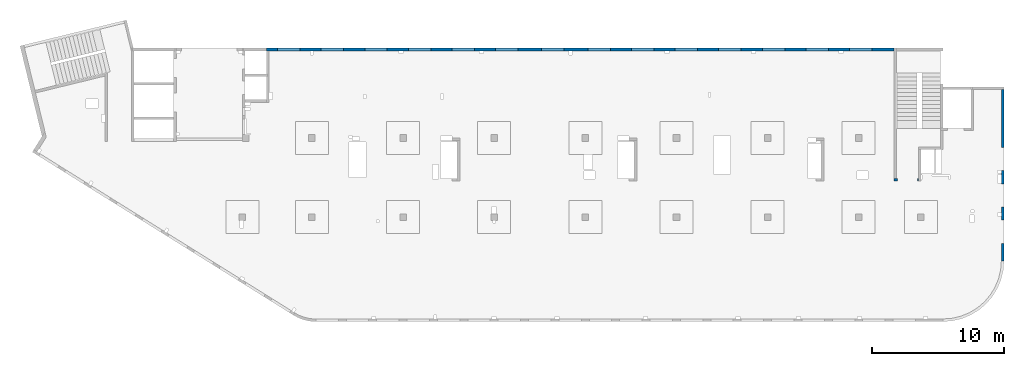
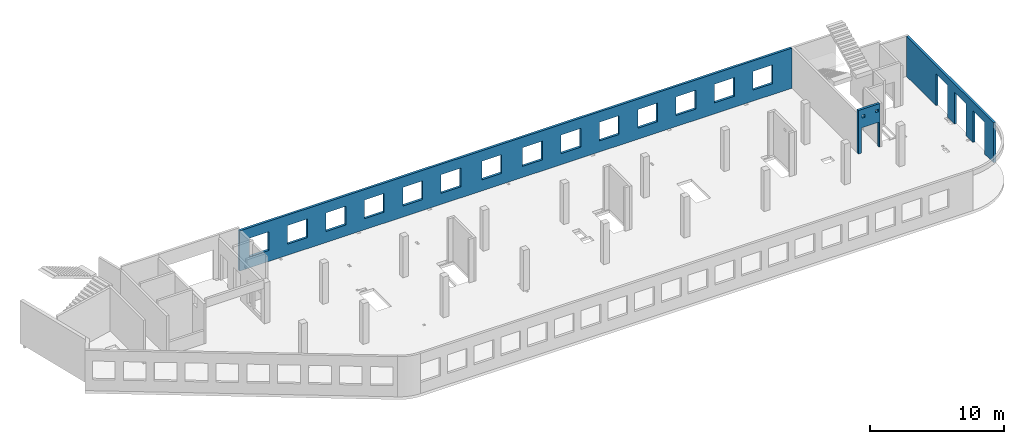
# One storey, part 7 of 7: 3 walls, 20 openings.
"""IFC4 building model written with IfcOpenShell, lengths in millimetres."""

from ifc_helpers import new_model, entity, si_unit, converted_unit, derived_unit, direction, frame, origin, place, context, subcontext, project, spatial, indexed_curve, outline, extrude, polygons, material, type_object, element, save


model = new_model("IFC4")

# Units and contexts
model_context = context("Model", 3, precision=0.01, world=origin(), true_north=direction((6.12303176911189e-17, 1.0)))
plan_context = context("Plan", 3, precision=0.01, world=origin(), true_north=direction((6.12303176911189e-17, 1.0)))
body_context = subcontext(model_context, "Body", "Model", "MODEL_VIEW")
ifc_project = project(units=[si_unit("LENGTHUNIT", "METRE", prefix="MILLI"), si_unit("AREAUNIT", "SQUARE_METRE"), si_unit("VOLUMEUNIT", "CUBIC_METRE"), converted_unit("PLANEANGLEUNIT", "DEGREE", entity("IfcRatioMeasure", 0.0174532925199433), si_unit("PLANEANGLEUNIT", "RADIAN"), dimensions=[0, 0, 0, 0, 0, 0, 0]), si_unit("MASSUNIT", "GRAM", prefix="KILO"), derived_unit("MASSDENSITYUNIT", [(si_unit("MASSUNIT", "GRAM", prefix="KILO"), 1), (si_unit("LENGTHUNIT", "METRE"), -3)]), derived_unit("MOMENTOFINERTIAUNIT", [(si_unit("LENGTHUNIT", "METRE"), 4)]), si_unit("TIMEUNIT", "SECOND"), si_unit("FREQUENCYUNIT", "HERTZ"), si_unit("THERMODYNAMICTEMPERATUREUNIT", "DEGREE_CELSIUS"), derived_unit("THERMALTRANSMITTANCEUNIT", [(si_unit("MASSUNIT", "GRAM", prefix="KILO"), 1), (si_unit("THERMODYNAMICTEMPERATUREUNIT", "KELVIN"), -1), (si_unit("TIMEUNIT", "SECOND"), -3)]), derived_unit("VOLUMETRICFLOWRATEUNIT", [(si_unit("LENGTHUNIT", "METRE"), 3), (si_unit("TIMEUNIT", "SECOND"), -1)]), derived_unit("MASSFLOWRATEUNIT", [(si_unit("MASSUNIT", "GRAM", prefix="KILO"), 1), (si_unit("TIMEUNIT", "SECOND"), -1)]), derived_unit("ROTATIONALFREQUENCYUNIT", [(si_unit("TIMEUNIT", "SECOND"), -1)]), si_unit("ELECTRICCURRENTUNIT", "AMPERE"), si_unit("ELECTRICVOLTAGEUNIT", "VOLT"), si_unit("POWERUNIT", "WATT"), si_unit("FORCEUNIT", "NEWTON", prefix="KILO"), si_unit("ILLUMINANCEUNIT", "LUX"), si_unit("LUMINOUSFLUXUNIT", "LUMEN"), si_unit("LUMINOUSINTENSITYUNIT", "CANDELA"), derived_unit("USERDEFINED", [(si_unit("MASSUNIT", "GRAM", prefix="KILO"), -1), (si_unit("LENGTHUNIT", "METRE"), -2), (si_unit("TIMEUNIT", "SECOND"), 3), (si_unit("LUMINOUSFLUXUNIT", "LUMEN"), 1)]), derived_unit("LINEARVELOCITYUNIT", [(si_unit("LENGTHUNIT", "METRE"), 1), (si_unit("TIMEUNIT", "SECOND"), -1)]), si_unit("PRESSUREUNIT", "PASCAL"), derived_unit("USERDEFINED", [(si_unit("LENGTHUNIT", "METRE"), -2), (si_unit("MASSUNIT", "GRAM", prefix="KILO"), 1), (si_unit("TIMEUNIT", "SECOND"), -2)]), derived_unit("LINEARFORCEUNIT", [(si_unit("MASSUNIT", "GRAM", prefix="KILO"), 1), (si_unit("LENGTHUNIT", "METRE"), 1), (si_unit("TIMEUNIT", "SECOND"), -2), (si_unit("LENGTHUNIT", "METRE"), -1)]), derived_unit("PLANARFORCEUNIT", [(si_unit("MASSUNIT", "GRAM", prefix="KILO"), 1), (si_unit("LENGTHUNIT", "METRE"), 1), (si_unit("TIMEUNIT", "SECOND"), -2), (si_unit("LENGTHUNIT", "METRE"), -2)])], contexts=[model_context, plan_context])

# Site, building, storey
site_placement = place(None, origin())
site = spatial("IfcSite", under=ifc_project, at=site_placement, CompositionType="ELEMENT")
building_placement = place(site_placement, origin())
building = spatial("IfcBuilding", under=site, at=building_placement, CompositionType="ELEMENT")
storey_placement = place(building_placement, frame((0.0, 0.0, 12000.0)))
storey = spatial("IfcBuildingStorey", under=building, at=storey_placement, CompositionType="ELEMENT", Elevation=12000.0)

# Wall, openings
ifc_material = material()
wall_type = type_object("IfcWallType", PredefinedType="STANDARD")
wall_1_placement = place(storey_placement, frame((73469.9994506836, 17369.9992263554, -150.0), z_axis=(0.0, 0.0, 1.0), x_axis=(0.0, -1.0, 0.0)))
wall_1 = element("IfcWall", 1, at=wall_1_placement, inside=storey, type_object=wall_type, material=ifc_material, PredefinedType="NOTDEFINED", context=body_context, shape_type="Tessellation", body=[
    polygons([(12970.0, -99.9999999999918, 0.0), (12970.0, -99.9999999999918, 3200.0), (12970.0, -99.9999999999918, 3650.0), (9560.00000000002, -99.9999999999877, 3650.0), (9360.00000000002, -99.999999999988, 3650.0), (7085.00000000004, -99.999999999991, 3650.0), (6485.00000000003, -99.9999999999918, 3650.0), (6320.00000000002, -99.999999999992, 3650.0), (6120.00000000002, -99.9999999999923, 3650.0), (0.0, -99.9999999999831, 3650.0), (0.0, -99.9999999999831, 0.0), (4394.99999999951, -99.9999999999946, 0.0), (4394.99999999951, -100.000000000003, 2900.0), (6144.99999999951, -100.000000000001, 2900.0), (6144.99999999951, -99.9999999999923, 0.0), (6320.00000000002, -99.999999999992, 0.0), (6485.00000000003, -99.9999999999918, 0.0), (7085.00000000004, -99.999999999991, 0.0), (7144.99999999951, -99.9999999999909, 0.0), (7144.99999999951, -99.9999999999996, 2900.0), (8894.99999999951, -99.9999999999972, 2900.0), (8894.99999999951, -99.9999999999886, 0.0), (9360.00000000002, -99.999999999988, 0.0), (9560.00000000003, -99.9999999999877, 0.0), (9894.99999999951, -99.9999999999959, 0.0), (9894.99999999951, -99.9999999999959, 2900.0), (11644.9999999995, -99.9999999999936, 2900.0), (11644.9999999995, -99.9999999999936, 0.0), (12970.0, 100.000000000006, 3650.0), (12970.0, 100.000000000006, 3200.0), (12970.0, 100.000000000006, 0.0), (11644.9999999995, 100.000000000004, 0.0), (11644.9999999995, 100.000000000316, 2900.0), (9894.99999999951, 100.000000000314, 2900.0), (9894.99999999951, 100.000000000002, 0.0), (8894.99999999951, 100.000000000001, 0.0), (8894.99999999951, 100.00000000033, 2900.0), (7144.99999999951, 100.000000000327, 2900.0), (7144.99999999951, 99.9999999999983, 0.0), (6144.99999999951, 99.9999999999969, 0.0), (6144.99999999951, 100.000000000326, 2900.0), (4394.99999999951, 100.000000000324, 2900.0), (4394.99999999951, 99.9999999999946, 0.0), (0.0, 100.000000000006, 0.0), (0.0, 100.000000000006, 3650.0)], [[[1, 2, 3, 4, 5, 6, 7, 8, 9, 10, 11, 12, 13, 14, 15, 16, 17, 18, 19, 20, 21, 22, 23, 24, 25, 26, 27, 28]], [[29, 30, 31, 32, 33, 34, 35, 36, 37, 38, 39, 40, 41, 42, 43, 44, 45]], [[11, 44, 43, 12]], [[3, 2, 1, 31, 30, 29]], [[10, 9, 8, 7, 6, 5, 4, 3, 29, 45]], [[11, 10, 45, 44]], [[26, 34, 33, 27]], [[34, 26, 25, 35]], [[27, 33, 32, 28]], [[20, 38, 37, 21]], [[38, 20, 19, 39]], [[21, 37, 36, 22]], [[13, 42, 41, 14]], [[42, 13, 12, 43]], [[14, 41, 40, 15]], [[39, 19, 18, 17, 16, 15, 40]], [[35, 25, 24, 23, 22, 36]], [[31, 1, 28, 32]]], closed=True),
])
opening_1_placement = place(wall_1_placement, frame((17369.9992263554, -73469.9994506836, 150.0), z_axis=(0.0, 0.0, 1.0), x_axis=(0.0, 1.0, 0.0)))
element("IfcOpeningElement", 2, at=opening_1_placement, cuts=wall_1, PredefinedType="OPENING", context=body_context, shape_type="SweptSolid", body=[
    extrude(outline(indexed_curve([(-1449.99999999999, -874.999999999999), (1449.99999999999, -874.999999999999), (1449.99999999999, 875.0), (-1449.99999999999, 875.0), (-1449.99999999999, -874.999999999999)], self_intersect=False)), frame((73369.9994506836, 6599.99922635594, 1300.0), z_axis=(1.0, 0.0, 0.0), x_axis=(0.0, 0.0, -1.0)), (0.0, 0.0, 1.0), 200.000000000968),
])
opening_2_placement = place(wall_1_placement, frame((17369.9992263554, -73469.9994506836, 150.0), z_axis=(0.0, 0.0, 1.0), x_axis=(0.0, 1.0, 0.0)))
element("IfcOpeningElement", 3, at=opening_2_placement, cuts=wall_1, PredefinedType="OPENING", context=body_context, shape_type="SweptSolid", body=[
    extrude(outline(indexed_curve([(-1449.99999999999, -875.0), (1449.99999999999, -875.0), (1449.99999999999, 874.999999999999), (-1449.99999999999, 874.999999999999), (-1449.99999999999, -875.0)], self_intersect=False)), frame((73369.9994506836, 9349.99922635594, 1300.0), z_axis=(1.0, 0.0, 0.0), x_axis=(0.0, 0.0, -1.0)), (0.0, 0.0, 1.0), 200.000000000968),
])
opening_3_placement = place(wall_1_placement, frame((17369.9992263554, -73469.9994506836, 150.0), z_axis=(0.0, 0.0, 1.0), x_axis=(0.0, 1.0, 0.0)))
element("IfcOpeningElement", 4, at=opening_3_placement, cuts=wall_1, PredefinedType="OPENING", context=body_context, shape_type="SweptSolid", body=[
    extrude(outline(indexed_curve([(-1449.99999999999, -875.0), (1449.99999999999, -875.0), (1449.99999999999, 875.0), (-1449.99999999999, 875.0), (-1449.99999999999, -875.0)], self_intersect=False)), frame((73369.9994506836, 12099.9992263559, 1300.0), z_axis=(1.0, 0.0, 0.0), x_axis=(0.0, 0.0, -1.0)), (0.0, 0.0, 1.0), 200.000000000968),
])

wall_2_placement = place(storey_placement, frame((67080.0002685547, 10524.9992263555, -150.0), z_axis=(0.0, 0.0, 1.0), x_axis=(-1.0, 0.0, 0.0)))
wall_2 = element("IfcWall", 5, at=wall_2_placement, inside=storey, type_object=wall_type, material=ifc_material, PredefinedType="NOTDEFINED", context=body_context, shape_type="Tessellation", body=[
    polygons([(1849.99999999999, -100.000000000001, 3950.0), (-9.772240076716e-13, -100.000000000001, 3950.0), (-9.772240076716e-13, -100.000000000001, 0.0), (74.9999999999906, -100.000000000001, 0.0), (74.9999999999906, -100.000000000001, 2279.99999999805), (1575.0, -100.000000000001, 2279.99999999804), (1575.0, -100.000000000003, 0.0), (1650.0, -100.000000000003, 0.0), (1849.99999999999, -100.000000000001, 0.0), (1849.99999999999, -100.000000000001, 3650.0), (125.000000000014, -100.000000000322, 3490.0), (375.000000000009, -100.000000000324, 3490.0), (375.000000000009, -100.000000000324, 3240.00000000001), (125.000000000014, -100.000000000322, 3240.00000000001), (1275.0, -100.000000000322, 3400.0), (1524.99999999999, -100.000000000322, 3400.0), (1524.99999999999, -100.000000000322, 3150.00000000001), (1275.0, -100.000000000322, 3150.00000000001), (-1.61109744921212e-12, 99.9999999999989, 3950.0), (1849.99999999999, 99.9999999999989, 3950.0), (1849.99999999999, 99.9999999999989, 0.0), (1575.0, 99.9999999999968, 0.0), (1575.0, 99.9999999999968, 2279.99999999804), (74.99999999999, 99.9999999999989, 2279.99999999805), (74.99999999999, 99.9999999999989, 0.0), (-1.61109744921212e-12, 99.9999999999989, 0.0), (375.000000000008, 99.9999999999968, 3490.0), (125.000000000013, 99.9999999999968, 3490.0), (125.000000000013, 99.9999999999968, 3240.00000000001), (375.000000000008, 99.9999999999968, 3240.00000000001), (1524.99999999999, 99.9999999999968, 3400.0), (1275.0, 99.9999999999989, 3400.0), (1275.0, 99.9999999999989, 3150.00000000001), (1524.99999999999, 99.9999999999968, 3150.00000000001)], [[[1, 2, 3, 4, 5, 6, 7, 8, 9, 10], [11, 12, 13, 14], [15, 16, 17, 18]], [[19, 20, 21, 22, 23, 24, 25, 26], [27, 28, 29, 30], [31, 32, 33, 34]], [[3, 26, 25, 4]], [[2, 1, 20, 19]], [[3, 2, 19, 26]], [[1, 10, 9, 21, 20]], [[12, 11, 28, 27]], [[12, 27, 30, 13]], [[13, 30, 29, 14]], [[28, 11, 14, 29]], [[16, 15, 32, 31]], [[16, 31, 34, 17]], [[17, 34, 33, 18]], [[32, 15, 18, 33]], [[5, 24, 23, 6]], [[6, 23, 22, 7]], [[24, 5, 4, 25]], [[21, 9, 8, 7, 22]]], closed=True),
])
opening_4_placement = place(wall_2_placement, frame((67080.0002685547, 10524.9992263555, 150.0), z_axis=(0.0, 0.0, 1.0), x_axis=(-1.0, 0.0, 0.0)))
element("IfcOpeningElement", 6, at=opening_4_placement, cuts=wall_2, PredefinedType="OPENING", context=body_context, shape_type="SweptSolid", body=[
    extrude(outline(indexed_curve([(-750.000000000003, -1139.99999999902), (749.999999999994, -1139.99999999902), (749.999999999994, 1139.99999999902), (-750.000000000003, 1139.99999999902), (-750.000000000003, -1139.99999999902)], self_intersect=False)), frame((66255.0002685547, 10724.9992263575, 990.0), z_axis=(0.0, -1.0, 0.0), x_axis=(-1.0, 0.0, 0.0)), (0.0, 0.0, 1.0), 400.000000001943),
])
opening_5_placement = place(wall_2_placement, frame((67080.0002685547, 10524.9992263555, 150.0), z_axis=(0.0, 0.0, 1.0), x_axis=(-1.0, 0.0, 0.0)))
element("IfcOpeningElement", 7, at=opening_5_placement, cuts=wall_2, PredefinedType="OPENING", context=body_context, shape_type="SweptSolid", body=[
    extrude(outline(indexed_curve([(-125.000000000006, -124.999999999993), (124.999999999998, -124.999999999993), (124.999999999998, 124.999999999993), (-125.000000000006, 124.999999999993), (-125.000000000006, -124.999999999993)], self_intersect=False)), frame((65680.0002685547, 10624.9992263565, 3125.0), z_axis=(0.0, -1.0, 0.0), x_axis=(-1.0, 0.0, 0.0)), (0.0, 0.0, 1.0), 200.000000000962),
])
opening_6_placement = place(wall_2_placement, frame((67080.0002685547, 10524.9992263555, 150.0), z_axis=(0.0, 0.0, 1.0), x_axis=(-1.0, 0.0, 0.0)))
element("IfcOpeningElement", 8, at=opening_6_placement, cuts=wall_2, PredefinedType="OPENING", context=body_context, shape_type="SweptSolid", body=[
    extrude(outline(indexed_curve([(-125.000000000006, -124.999999999993), (124.999999999998, -124.999999999993), (124.999999999998, 124.999999999993), (-125.000000000006, 124.999999999993), (-125.000000000006, -124.999999999993)], self_intersect=False)), frame((66830.0002685547, 10624.9992263565, 3215.0), z_axis=(0.0, -1.0, 0.0), x_axis=(-1.0, 0.0, 0.0)), (0.0, 0.0, 1.0), 200.000000000962),
])

wall_3_placement = place(storey_placement, frame((65230.0002685547, 20399.9998657227, -150.0), z_axis=(0.0, 0.0, 1.0), x_axis=(-1.0, 0.0, 0.0)))
wall_3 = element("IfcWall", 9, at=wall_3_placement, inside=storey, type_object=wall_type, material=ifc_material, PredefinedType="NOTDEFINED", context=body_context, shape_type="Tessellation", body=[
    polygons([(8.66293703438714e-12, -99.9999999999989, 0.0), (47505.0, -99.9999999999989, 0.0), (47505.0, -99.9999999999989, 3650.0), (47405.0, -99.9999999999989, 3650.0), (8.66293703438714e-12, -99.9999999999989, 3650.0), (28460.0, -100.000000000319, 2700.0), (30160.0, -100.000000000319, 2700.0), (30160.0, -100.000000000319, 1000.00000000001), (28460.0, -100.000000000319, 1000.00000000001), (1660.00000000009, -100.000000000319, 2700.0), (3360.00000000009, -100.000000000319, 2700.0), (3360.00000000009, -100.000000000319, 1000.00000000001), (1660.00000000009, -100.000000000319, 1000.00000000001), (4960.00000000009, -100.000000000319, 2700.0), (6660.00000000009, -100.000000000319, 2700.0), (6660.00000000009, -100.000000000319, 1000.00000000001), (4960.00000000009, -100.000000000319, 1000.00000000001), (8260.00000000008, -100.000000000319, 2700.0), (9960.00000000008, -100.000000000319, 2700.0), (9960.00000000008, -100.000000000319, 1000.00000000001), (8260.00000000008, -100.000000000319, 1000.00000000001), (11560.0000000001, -100.000000000319, 2700.0), (13260.0000000001, -100.000000000319, 2700.0), (13260.0000000001, -100.000000000319, 1000.00000000001), (11560.0000000001, -100.000000000319, 1000.00000000001), (14860.0000000001, -100.000000000319, 2700.0), (16560.0000000001, -100.000000000319, 2700.0), (16560.0000000001, -100.000000000319, 1000.00000000001), (14860.0000000001, -100.000000000319, 1000.00000000001), (18160.0000000001, -100.000000000319, 2700.0), (19860.0000000001, -100.000000000319, 2700.0), (19860.0000000001, -100.000000000319, 1000.00000000001), (18160.0000000001, -100.000000000319, 1000.00000000001), (21460.0000000001, -100.000000000319, 2700.0), (23160.0000000001, -100.000000000319, 2700.0), (23160.0000000001, -100.000000000319, 1000.00000000001), (21460.0000000001, -100.000000000319, 1000.00000000001), (24960.0000000001, -100.000000000319, 2700.0), (26660.0000000001, -100.000000000319, 2700.0), (26660.0000000001, -100.000000000319, 1000.00000000001), (24960.0000000001, -100.000000000319, 1000.00000000001), (31760.0000000001, -100.000000000319, 2700.0), (33460.0000000001, -100.000000000319, 2700.0), (33460.0000000001, -100.000000000319, 1000.00000000001), (31760.0000000001, -100.000000000319, 1000.00000000001), (35060.0000000001, -100.000000000319, 2700.0), (36760.0000000001, -100.000000000319, 2700.0), (36760.0000000001, -100.000000000319, 1000.00000000001), (35060.0000000001, -100.000000000319, 1000.00000000001), (38360.0000000001, -100.000000000319, 2700.0), (40060.0000000001, -100.000000000319, 2700.0), (40060.0000000001, -100.000000000319, 1000.00000000001), (38360.0000000001, -100.000000000319, 1000.00000000001), (41660.0, -100.000000000319, 2700.0), (43360.0, -100.000000000319, 2700.0), (43360.0, -100.000000000319, 1000.00000000001), (41660.0, -100.000000000319, 1000.00000000001), (44960.0, -100.000000000319, 2700.0), (46660.0, -100.000000000319, 2700.0), (46660.0, -100.000000000319, 1000.00000000001), (44960.0, -100.000000000319, 1000.00000000001), (30160.0, 99.9999999999989, 2699.99999999999), (28460.0, 99.9999999999989, 2699.99999999999), (28460.0, 99.9999999999989, 1000.00000000001), (30160.0, 99.9999999999989, 1000.00000000001), (3360.00000000009, 99.9999999999989, 2699.99999999999), (1660.00000000009, 99.9999999999989, 2699.99999999999), (1660.00000000009, 99.9999999999989, 1000.00000000001), (3360.00000000009, 99.9999999999989, 1000.00000000001), (6660.00000000009, 99.9999999999989, 2699.99999999999), (4960.00000000009, 99.9999999999989, 2699.99999999999), (4960.00000000009, 99.9999999999989, 1000.00000000001), (6660.00000000009, 99.9999999999989, 1000.00000000001), (9960.00000000008, 99.9999999999989, 2699.99999999999), (8260.00000000008, 99.9999999999989, 2699.99999999999), (8260.00000000008, 99.9999999999989, 1000.00000000001), (9960.00000000008, 99.9999999999989, 1000.00000000001), (13260.0000000001, 99.9999999999989, 2699.99999999999), (11560.0000000001, 99.9999999999989, 2699.99999999999), (11560.0000000001, 99.9999999999989, 1000.00000000001), (13260.0000000001, 99.9999999999989, 1000.00000000001), (16560.0000000001, 99.9999999999989, 2699.99999999999), (14860.0000000001, 99.9999999999989, 2699.99999999999), (14860.0000000001, 99.9999999999989, 1000.00000000001), (16560.0000000001, 99.9999999999989, 1000.00000000001), (19860.0000000001, 99.9999999999989, 2699.99999999999), (18160.0000000001, 99.9999999999989, 2699.99999999999), (18160.0000000001, 99.9999999999989, 1000.00000000001), (19860.0000000001, 99.9999999999989, 1000.00000000001), (23160.0000000001, 99.9999999999989, 2699.99999999999), (21460.0000000001, 99.9999999999989, 2699.99999999999), (21460.0000000001, 99.9999999999989, 1000.00000000001), (23160.0000000001, 99.9999999999989, 1000.00000000001), (26660.0000000001, 99.9999999999989, 2699.99999999999), (24960.0000000001, 99.9999999999989, 2699.99999999999), (24960.0000000001, 99.9999999999989, 1000.00000000001), (26660.0000000001, 99.9999999999989, 1000.00000000001), (33460.0000000001, 99.9999999999989, 2699.99999999999), (31760.0000000001, 99.9999999999989, 2699.99999999999), (31760.0000000001, 99.9999999999989, 1000.00000000001), (33460.0000000001, 99.9999999999989, 1000.00000000001), (36760.0000000001, 99.9999999999989, 2699.99999999999), (35060.0000000001, 99.9999999999989, 2699.99999999999), (35060.0000000001, 99.9999999999989, 1000.00000000001), (36760.0000000001, 99.9999999999989, 1000.00000000001), (40060.0000000001, 99.9999999999989, 2699.99999999999), (38360.0000000001, 99.9999999999989, 2699.99999999999), (38360.0000000001, 99.9999999999989, 1000.00000000001), (40060.0000000001, 99.9999999999989, 1000.00000000001), (43360.0, 99.9999999999989, 2699.99999999999), (41660.0, 99.9999999999989, 2699.99999999999), (41660.0, 99.9999999999989, 1000.00000000001), (43360.0, 99.9999999999989, 1000.00000000001), (46660.0, 99.9999999999989, 2699.99999999999), (44960.0, 99.9999999999989, 2699.99999999999), (44960.0, 99.9999999999989, 1000.00000000001), (46660.0, 99.9999999999989, 1000.00000000001), (8.66293703438714e-12, 99.9999999999989, 0.0), (8.66293703438714e-12, 99.9999999999989, 3650.0), (47305.0, 99.9999999999989, 3650.0), (47405.0, 99.9999999999989, 3650.0), (47505.0, 99.9999999999989, 3650.0), (47505.0, 99.9999999999989, 0.0), (47305.0, 99.9999999999989, 0.0)], [[[1, 2, 3, 4, 5], [6, 7, 8, 9], [10, 11, 12, 13], [14, 15, 16, 17], [18, 19, 20, 21], [22, 23, 24, 25], [26, 27, 28, 29], [30, 31, 32, 33], [34, 35, 36, 37], [38, 39, 40, 41], [42, 43, 44, 45], [46, 47, 48, 49], [50, 51, 52, 53], [54, 55, 56, 57], [58, 59, 60, 61]], [[118, 119, 120, 121, 122, 123, 124], [62, 63, 64, 65], [66, 67, 68, 69], [70, 71, 72, 73], [74, 75, 76, 77], [78, 79, 80, 81], [82, 83, 84, 85], [86, 87, 88, 89], [90, 91, 92, 93], [94, 95, 96, 97], [98, 99, 100, 101], [102, 103, 104, 105], [106, 107, 108, 109], [110, 111, 112, 113], [114, 115, 116, 117]], [[2, 1, 118, 124, 123]], [[5, 4, 3, 122, 121, 120, 119]], [[7, 6, 63, 62]], [[7, 62, 65, 8]], [[8, 65, 64, 9]], [[63, 6, 9, 64]], [[11, 10, 67, 66]], [[11, 66, 69, 12]], [[12, 69, 68, 13]], [[67, 10, 13, 68]], [[15, 14, 71, 70]], [[15, 70, 73, 16]], [[16, 73, 72, 17]], [[71, 14, 17, 72]], [[19, 18, 75, 74]], [[19, 74, 77, 20]], [[20, 77, 76, 21]], [[75, 18, 21, 76]], [[23, 22, 79, 78]], [[23, 78, 81, 24]], [[24, 81, 80, 25]], [[79, 22, 25, 80]], [[27, 26, 83, 82]], [[27, 82, 85, 28]], [[28, 85, 84, 29]], [[83, 26, 29, 84]], [[31, 30, 87, 86]], [[31, 86, 89, 32]], [[32, 89, 88, 33]], [[87, 30, 33, 88]], [[35, 34, 91, 90]], [[35, 90, 93, 36]], [[36, 93, 92, 37]], [[91, 34, 37, 92]], [[39, 38, 95, 94]], [[39, 94, 97, 40]], [[40, 97, 96, 41]], [[95, 38, 41, 96]], [[43, 42, 99, 98]], [[43, 98, 101, 44]], [[44, 101, 100, 45]], [[99, 42, 45, 100]], [[47, 46, 103, 102]], [[47, 102, 105, 48]], [[48, 105, 104, 49]], [[103, 46, 49, 104]], [[51, 50, 107, 106]], [[51, 106, 109, 52]], [[52, 109, 108, 53]], [[107, 50, 53, 108]], [[55, 54, 111, 110]], [[55, 110, 113, 56]], [[56, 113, 112, 57]], [[111, 54, 57, 112]], [[59, 58, 115, 114]], [[59, 114, 117, 60]], [[60, 117, 116, 61]], [[115, 58, 61, 116]], [[1, 5, 119, 118]], [[3, 2, 123, 122]]], closed=True),
])
opening_7_placement = place(wall_3_placement, frame((65230.0002685547, 20399.9998657227, 150.0), z_axis=(0.0, 0.0, 1.0), x_axis=(-1.0, 0.0, 0.0)))
element("IfcOpeningElement", 10, at=opening_7_placement, cuts=wall_3, PredefinedType="OPENING", context=body_context, shape_type="SweptSolid", body=[
    extrude(outline(indexed_curve([(-850.000000000002, -849.999999999995), (850.0, -849.999999999995), (850.0, 849.999999999993), (-850.000000000002, 849.999999999993), (-850.000000000002, -849.999999999995)], self_intersect=False)), frame((19420.0002685547, 20499.9998657236, 1700.0), z_axis=(0.0, -1.0, 0.0), x_axis=(-1.0, 0.0, 0.0)), (0.0, 0.0, 1.0), 200.000000000959),
])
opening_8_placement = place(wall_3_placement, frame((65230.0002685547, 20399.9998657227, 150.0), z_axis=(0.0, 0.0, 1.0), x_axis=(-1.0, 0.0, 0.0)))
element("IfcOpeningElement", 11, at=opening_8_placement, cuts=wall_3, PredefinedType="OPENING", context=body_context, shape_type="SweptSolid", body=[
    extrude(outline(indexed_curve([(-850.000000000002, -849.999999999995), (849.999999999997, -849.999999999995), (849.999999999997, 849.999999999993), (-850.000000000002, 849.999999999993), (-850.000000000002, -849.999999999995)], self_intersect=False)), frame((22720.0002685547, 20499.9998657236, 1700.0), z_axis=(0.0, -1.0, 0.0), x_axis=(-1.0, 0.0, 0.0)), (0.0, 0.0, 1.0), 200.000000000959),
])
opening_9_placement = place(wall_3_placement, frame((65230.0002685547, 20399.9998657227, 150.0), z_axis=(0.0, 0.0, 1.0), x_axis=(-1.0, 0.0, 0.0)))
element("IfcOpeningElement", 12, at=opening_9_placement, cuts=wall_3, PredefinedType="OPENING", context=body_context, shape_type="SweptSolid", body=[
    extrude(outline(indexed_curve([(-850.000000000002, -849.999999999995), (849.999999999997, -849.999999999995), (849.999999999997, 849.999999999993), (-850.000000000002, 849.999999999993), (-850.000000000002, -849.999999999995)], self_intersect=False)), frame((26020.0002685547, 20499.9998657236, 1700.0), z_axis=(0.0, -1.0, 0.0), x_axis=(-1.0, 0.0, 0.0)), (0.0, 0.0, 1.0), 200.000000000959),
])
opening_10_placement = place(wall_3_placement, frame((65230.0002685547, 20399.9998657227, 150.0), z_axis=(0.0, 0.0, 1.0), x_axis=(-1.0, 0.0, 0.0)))
element("IfcOpeningElement", 13, at=opening_10_placement, cuts=wall_3, PredefinedType="OPENING", context=body_context, shape_type="SweptSolid", body=[
    extrude(outline(indexed_curve([(-850.000000000002, -849.999999999995), (849.999999999997, -849.999999999995), (849.999999999997, 849.999999999993), (-850.000000000002, 849.999999999993), (-850.000000000002, -849.999999999995)], self_intersect=False)), frame((29320.0002685547, 20499.9998657236, 1700.0), z_axis=(0.0, -1.0, 0.0), x_axis=(-1.0, 0.0, 0.0)), (0.0, 0.0, 1.0), 200.000000000959),
])
opening_11_placement = place(wall_3_placement, frame((65230.0002685547, 20399.9998657227, 150.0), z_axis=(0.0, 0.0, 1.0), x_axis=(-1.0, 0.0, 0.0)))
element("IfcOpeningElement", 14, at=opening_11_placement, cuts=wall_3, PredefinedType="OPENING", context=body_context, shape_type="SweptSolid", body=[
    extrude(outline(indexed_curve([(-849.999999999997, -849.999999999995), (850.000000000002, -849.999999999995), (850.000000000002, 849.999999999993), (-849.999999999997, 849.999999999993), (-849.999999999997, -849.999999999995)], self_intersect=False)), frame((32620.0002685547, 20499.9998657236, 1700.0), z_axis=(0.0, -1.0, 0.0), x_axis=(-1.0, 0.0, 0.0)), (0.0, 0.0, 1.0), 200.000000000959),
])
opening_12_placement = place(wall_3_placement, frame((65230.0002685547, 20399.9998657227, 150.0), z_axis=(0.0, 0.0, 1.0), x_axis=(-1.0, 0.0, 0.0)))
element("IfcOpeningElement", 15, at=opening_12_placement, cuts=wall_3, PredefinedType="OPENING", context=body_context, shape_type="SweptSolid", body=[
    extrude(outline(indexed_curve([(-849.999999999997, -849.999999999995), (850.000000000006, -849.999999999995), (850.000000000006, 849.999999999993), (-849.999999999997, 849.999999999993), (-849.999999999997, -849.999999999995)], self_intersect=False)), frame((39420.0002685547, 20499.9998657236, 1700.0), z_axis=(0.0, -1.0, 0.0), x_axis=(-1.0, 0.0, 0.0)), (0.0, 0.0, 1.0), 200.000000000959),
])
opening_13_placement = place(wall_3_placement, frame((65230.0002685547, 20399.9998657227, 150.0), z_axis=(0.0, 0.0, 1.0), x_axis=(-1.0, 0.0, 0.0)))
element("IfcOpeningElement", 16, at=opening_13_placement, cuts=wall_3, PredefinedType="OPENING", context=body_context, shape_type="SweptSolid", body=[
    extrude(outline(indexed_curve([(-850.000000000006, -849.999999999995), (849.999999999997, -849.999999999995), (849.999999999997, 849.999999999993), (-850.000000000006, 849.999999999993), (-850.000000000006, -849.999999999995)], self_intersect=False)), frame((42920.0002685547, 20499.9998657236, 1700.0), z_axis=(0.0, -1.0, 0.0), x_axis=(-1.0, 0.0, 0.0)), (0.0, 0.0, 1.0), 200.000000000959),
])
opening_14_placement = place(wall_3_placement, frame((65230.0002685547, 20399.9998657227, 150.0), z_axis=(0.0, 0.0, 1.0), x_axis=(-1.0, 0.0, 0.0)))
element("IfcOpeningElement", 17, at=opening_14_placement, cuts=wall_3, PredefinedType="OPENING", context=body_context, shape_type="SweptSolid", body=[
    extrude(outline(indexed_curve([(-849.999999999997, -849.999999999995), (850.000000000006, -849.999999999995), (850.000000000006, 849.999999999993), (-849.999999999997, 849.999999999993), (-849.999999999997, -849.999999999995)], self_intersect=False)), frame((46220.0002685547, 20499.9998657236, 1700.0), z_axis=(0.0, -1.0, 0.0), x_axis=(-1.0, 0.0, 0.0)), (0.0, 0.0, 1.0), 200.000000000959),
])
opening_15_placement = place(wall_3_placement, frame((65230.0002685547, 20399.9998657227, 150.0), z_axis=(0.0, 0.0, 1.0), x_axis=(-1.0, 0.0, 0.0)))
element("IfcOpeningElement", 18, at=opening_15_placement, cuts=wall_3, PredefinedType="OPENING", context=body_context, shape_type="SweptSolid", body=[
    extrude(outline(indexed_curve([(-849.999999999997, -849.999999999995), (850.000000000006, -849.999999999995), (850.000000000006, 849.999999999993), (-849.999999999997, 849.999999999993), (-849.999999999997, -849.999999999995)], self_intersect=False)), frame((49520.0002685547, 20499.9998657236, 1700.0), z_axis=(0.0, -1.0, 0.0), x_axis=(-1.0, 0.0, 0.0)), (0.0, 0.0, 1.0), 200.000000000959),
])
opening_16_placement = place(wall_3_placement, frame((65230.0002685547, 20399.9998657227, 150.0), z_axis=(0.0, 0.0, 1.0), x_axis=(-1.0, 0.0, 0.0)))
element("IfcOpeningElement", 19, at=opening_16_placement, cuts=wall_3, PredefinedType="OPENING", context=body_context, shape_type="SweptSolid", body=[
    extrude(outline(indexed_curve([(-849.999999999997, -849.999999999995), (850.000000000006, -849.999999999995), (850.000000000006, 849.999999999993), (-849.999999999997, 849.999999999993), (-849.999999999997, -849.999999999995)], self_intersect=False)), frame((52820.0002685547, 20499.9998657236, 1700.0), z_axis=(0.0, -1.0, 0.0), x_axis=(-1.0, 0.0, 0.0)), (0.0, 0.0, 1.0), 200.000000000959),
])
opening_17_placement = place(wall_3_placement, frame((65230.0002685547, 20399.9998657227, 150.0), z_axis=(0.0, 0.0, 1.0), x_axis=(-1.0, 0.0, 0.0)))
element("IfcOpeningElement", 20, at=opening_17_placement, cuts=wall_3, PredefinedType="OPENING", context=body_context, shape_type="SweptSolid", body=[
    extrude(outline(indexed_curve([(-849.999999999997, -849.999999999995), (850.000000000006, -849.999999999995), (850.000000000006, 849.999999999993), (-849.999999999997, 849.999999999993), (-849.999999999997, -849.999999999995)], self_intersect=False)), frame((56120.0002685547, 20499.9998657236, 1700.0), z_axis=(0.0, -1.0, 0.0), x_axis=(-1.0, 0.0, 0.0)), (0.0, 0.0, 1.0), 200.000000000959),
])
opening_18_placement = place(wall_3_placement, frame((65230.0002685547, 20399.9998657227, 150.0), z_axis=(0.0, 0.0, 1.0), x_axis=(-1.0, 0.0, 0.0)))
element("IfcOpeningElement", 21, at=opening_18_placement, cuts=wall_3, PredefinedType="OPENING", context=body_context, shape_type="SweptSolid", body=[
    extrude(outline(indexed_curve([(-849.999999999997, -849.999999999995), (850.000000000006, -849.999999999995), (850.000000000006, 849.999999999993), (-849.999999999997, 849.999999999993), (-849.999999999997, -849.999999999995)], self_intersect=False)), frame((59420.0002685547, 20499.9998657236, 1700.0), z_axis=(0.0, -1.0, 0.0), x_axis=(-1.0, 0.0, 0.0)), (0.0, 0.0, 1.0), 200.000000000959),
])
opening_19_placement = place(wall_3_placement, frame((65230.0002685547, 20399.9998657227, 150.0), z_axis=(0.0, 0.0, 1.0), x_axis=(-1.0, 0.0, 0.0)))
element("IfcOpeningElement", 22, at=opening_19_placement, cuts=wall_3, PredefinedType="OPENING", context=body_context, shape_type="SweptSolid", body=[
    extrude(outline(indexed_curve([(-849.999999999997, -849.999999999995), (850.000000000006, -849.999999999995), (850.000000000006, 849.999999999993), (-849.999999999997, 849.999999999993), (-849.999999999997, -849.999999999995)], self_intersect=False)), frame((62720.0002685547, 20499.9998657236, 1700.0), z_axis=(0.0, -1.0, 0.0), x_axis=(-1.0, 0.0, 0.0)), (0.0, 0.0, 1.0), 200.000000000959),
])
opening_20_placement = place(wall_3_placement, frame((65230.0002685547, 20399.9998657227, 150.0), z_axis=(0.0, 0.0, 1.0), x_axis=(-1.0, 0.0, 0.0)))
element("IfcOpeningElement", 23, at=opening_20_placement, cuts=wall_3, PredefinedType="OPENING", context=body_context, shape_type="SweptSolid", body=[
    extrude(outline(indexed_curve([(-849.999999999997, -849.999999999995), (850.000000000002, -849.999999999995), (850.000000000002, 849.999999999993), (-849.999999999997, 849.999999999993), (-849.999999999997, -849.999999999995)], self_intersect=False)), frame((35920.0002685547, 20499.9998657236, 1700.0), z_axis=(0.0, -1.0, 0.0), x_axis=(-1.0, 0.0, 0.0)), (0.0, 0.0, 1.0), 200.000000000959),
])

save(model, "model.ifc")
